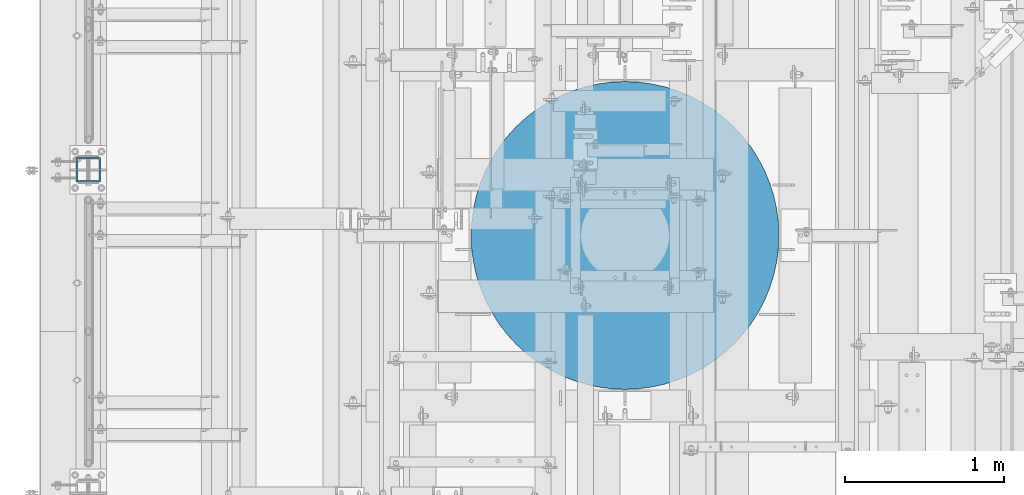
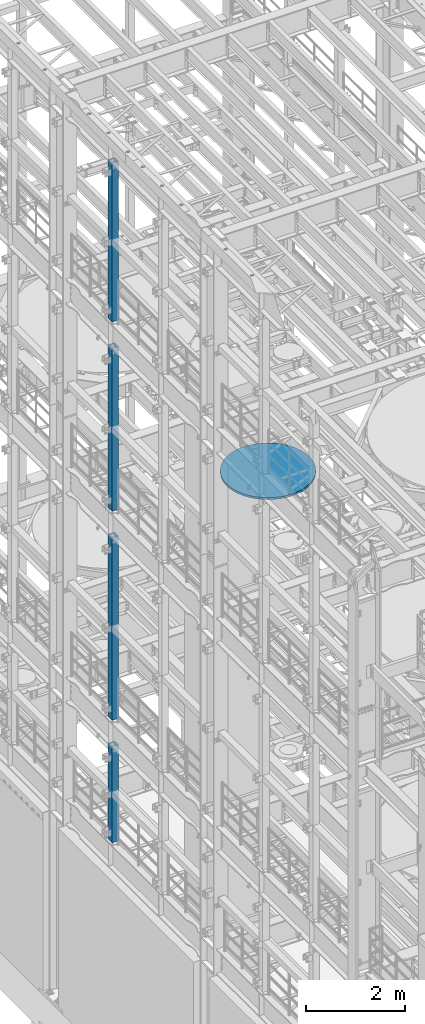
# One storey, part 703 of 1876: 6 columns, 6 elements without a shape of their own.
"""IFC2X3 building model written with IfcOpenShell, lengths in millimetres."""

import ifcopenshell
import ifcopenshell.guid

model = None  # the IFC model being written
_history = None  # IfcOwnerHistory: only IFC2X3 demands one
_inside = {}  # id of a spatial element -> (the spatial element, [elements in it])
_under = {}  # id of a project, library or spatial element -> (it, [spatial elements below it])
_declared = {}  # id of a project -> (the project, [libraries it declares])
_typed = {}  # id of a type object -> (the type object, [elements of that type])
_made_of = {}  # id of a material, layer set ... -> (it, [elements and type objects made of it])


def new_model(schema):
    """Start an empty IFC model of exactly this schema.

    Asked for "IFC4X3", IfcOpenShell would pick the latest addendum, in which some entities
    have other attributes; the version numbers below select the first issue.
    IFC2X3 requires an IfcOwnerHistory on every rooted entity: one is made here for all.
    """
    global model, _history
    if schema == "IFC4X3":
        model = ifcopenshell.file(schema_version=(4, 3, 0, 0))
    else:
        model = ifcopenshell.file(schema=schema)
    _inside.clear()
    _under.clear()
    _declared.clear()
    _typed.clear()
    _made_of.clear()
    _history = None
    if model.schema == "IFC2X3":
        org = make("IfcOrganization", Name="unknown")
        user = make(
            "IfcPersonAndOrganization",
            ThePerson=make("IfcPerson", FamilyName="unknown"),
            TheOrganization=org,
        )
        app = make(
            "IfcApplication",
            ApplicationDeveloper=org,
            Version="unknown",
            ApplicationFullName="unknown",
            ApplicationIdentifier="unknown",
        )
        _history = make(
            "IfcOwnerHistory",
            OwningUser=user,
            OwningApplication=app,
            ChangeAction="ADDED",
            CreationDate=0,
        )
    return model


def make(cls, **values):
    """One entity of the class cls with the attributes given. An attribute that is None is left unset."""
    return model.create_entity(
        cls, **{name: value for name, value in values.items() if value is not None}
    )


def rooted(cls, **values):
    """An entity with a GlobalId (a new one), such as an element, a storey or a relation."""
    return make(cls, GlobalId=ifcopenshell.guid.new(), OwnerHistory=_history, **values)


def si_unit(unit_type, name, prefix=None):
    """IfcSIUnit, for example si_unit("LENGTHUNIT", "METRE", prefix="MILLI")."""
    return make("IfcSIUnit", UnitType=unit_type, Prefix=prefix, Name=name)


def assignment(units):
    """IfcUnitAssignment: the units of a project."""
    return None if units is None else make("IfcUnitAssignment", Units=units)


def point(xyz):
    """IfcCartesianPoint."""
    return None if xyz is None else make("IfcCartesianPoint", Coordinates=xyz)


def direction(xyz):
    """IfcDirection."""
    return None if xyz is None else make("IfcDirection", DirectionRatios=xyz)


def frame(location, z_axis=None, x_axis=None):
    """IfcAxis2Placement3D, a coordinate frame: its origin and axes. An axis left out is left unset."""
    return make(
        "IfcAxis2Placement3D",
        Location=point(location),
        Axis=direction(z_axis),
        RefDirection=direction(x_axis),
    )


def origin_with_axes():
    """The frame at (0, 0, 0) with the z axis (0, 0, 1) and the x axis (1, 0, 0) written out."""
    return frame((0.0, 0.0, 0.0), z_axis=(0.0, 0.0, 1.0), x_axis=(1.0, 0.0, 0.0))


def place(relative_to, where):
    """IfcLocalPlacement: puts the frame where relative to a parent placement (None: the world)."""
    return make(
        "IfcLocalPlacement", PlacementRelTo=relative_to, RelativePlacement=where
    )


def context(
    kind, dimensions, precision=None, world=None, true_north=None, identifier=None
):
    """IfcGeometricRepresentationContext, for example the 3D "Model" context."""
    return make(
        "IfcGeometricRepresentationContext",
        ContextIdentifier=identifier,
        ContextType=kind,
        CoordinateSpaceDimension=dimensions,
        Precision=precision,
        WorldCoordinateSystem=world,
        TrueNorth=true_north,
    )


def subcontext(parent, identifier, kind, view, scale=None):
    """IfcGeometricRepresentationSubContext, for example "Body" below "Model"."""
    return make(
        "IfcGeometricRepresentationSubContext",
        ContextIdentifier=identifier,
        ContextType=kind,
        ParentContext=parent,
        TargetScale=scale,
        TargetView=view,
    )


def project(units=None, contexts=None):
    """IfcProject with its units and contexts."""
    return rooted(
        "IfcProject",
        Name="project",
        RepresentationContexts=contexts,
        UnitsInContext=assignment(units),
    )


def spatial(cls, under=None, at=None, **own):
    """A site, building, storey or space (cls), placed at a placement, below another one or the project."""
    s = rooted(cls, ObjectPlacement=at, **own)
    if under is not None:
        _under.setdefault(under.id(), (under, []))[1].append(s)
    return s


def faces_of(points, faces, orient=None, outer=None):
    """IfcFace entities. A face is a list of loops; a loop is a list of indices into points, from 0.

    orient and outer hold one flag for each loop. By default every Orientation is true, the
    first loop of a face is its IfcFaceOuterBound and the others are IfcFaceBound.
    """
    made = []
    for i, loops in enumerate(faces):
        bounds = []
        for j, loop in enumerate(loops):
            is_outer = j == 0 if outer is None else outer[i][j]
            bounds.append(
                make(
                    "IfcFaceOuterBound" if is_outer else "IfcFaceBound",
                    Bound=make("IfcPolyLoop", Polygon=[points[k] for k in loop]),
                    Orientation=True if orient is None else orient[i][j],
                )
            )
        made.append(make("IfcFace", Bounds=bounds))
    return made


def faceted_brep(points, faces, orient=None, outer=None, voids=None):
    """IfcFacetedBrep: a solid bounded by flat faces; with voids (closed shells), ...WithVoids."""
    shared = [point(p) for p in points]
    hull = make("IfcClosedShell", CfsFaces=faces_of(shared, faces, orient, outer))
    if voids is None:
        return make("IfcFacetedBrep", Outer=hull)
    return make(
        "IfcFacetedBrepWithVoids",
        Outer=hull,
        Voids=[
            make(cls, CfsFaces=faces_of(shared, fs, o, b)) for cls, fs, o, b in voids
        ],
    )


def shape(context_of_items, identifier, shape_type, items):
    """IfcShapeRepresentation: the items that make up one representation, for example the "Body"."""
    return make(
        "IfcShapeRepresentation",
        ContextOfItems=context_of_items,
        RepresentationIdentifier=identifier,
        RepresentationType=shape_type,
        Items=items,
    )


def material(Name=None, Category=None):
    """IfcMaterial."""
    return make("IfcMaterial", Name=Name, Category=Category)


def made_of(thing, what):
    """Note that an element or type object is made of a material, layer set ...; save() writes the relation."""
    if what is not None:
        _made_of.setdefault(what.id(), (what, []))[1].append(thing)
    return thing


def type_object(cls, material=None, **own):
    """A type object (cls), such as IfcWallType, which elements share."""
    return made_of(rooted(cls, **own), material)


def element(
    cls,
    number,
    at=None,
    inside=None,
    cuts=None,
    type_object=None,
    material=None,
    context=None,
    identifier="Body",
    shape_type=None,
    held_by="IfcProductDefinitionShape",
    body=None,
    shapes=None,
    **own,
):
    """One element of the class cls, such as IfcWall. Its Tag is "e" and its number.

    at: its placement. inside: the storey or other place that contains it. cuts: it is an
    opening in that element (IfcRelVoidsElement). A single representation is given by context,
    identifier, shape_type and body (its items); several are given by shapes. held_by: the class
    of the entity that holds the representations. save() writes the other relations.
    """
    e = rooted(cls, Tag="e%d" % number, ObjectPlacement=at, **own)
    if body is not None:
        shapes = [shape(context, identifier, shape_type, body)]
    if shapes is not None:
        e.Representation = make(held_by, Representations=shapes)
    if inside is not None:
        _inside.setdefault(inside.id(), (inside, []))[1].append(e)
    if cuts is not None:
        rooted(
            "IfcRelVoidsElement", RelatingBuildingElement=cuts, RelatedOpeningElement=e
        )
    if type_object is not None:
        _typed.setdefault(type_object.id(), (type_object, []))[1].append(e)
    return made_of(e, material)


def aggregate(whole, parts):
    """IfcRelAggregates: a whole, such as a stair, and the parts it consists of."""
    return rooted("IfcRelAggregates", RelatingObject=whole, RelatedObjects=parts)


def save(model, path):
    """Write the relations noted so far, then the file.

    IfcRelAggregates (storeys below a building ...), IfcRelContainedInSpatialStructure (elements
    in a storey), IfcRelDefinesByType, IfcRelAssociatesMaterial and IfcRelDeclares: one each for
    every whole, place, type object, material and project.
    """
    for whole, parts in _under.values():
        aggregate(whole, parts)
    for where, things in _inside.values():
        rooted(
            "IfcRelContainedInSpatialStructure",
            RelatedElements=things,
            RelatingStructure=where,
        )
    for kind, things in _typed.values():
        rooted("IfcRelDefinesByType", RelatedObjects=things, RelatingType=kind)
    for what, things in _made_of.values():
        rooted("IfcRelAssociatesMaterial", RelatedObjects=things, RelatingMaterial=what)
    for by, libraries in _declared.values():
        rooted("IfcRelDeclares", RelatingContext=by, RelatedDefinitions=libraries)
    model.write(path)


model = new_model("IFC2X3")

# Units and contexts
model_context = context("Model", 3, precision=1e-05, world=origin_with_axes())
body_context = subcontext(model_context, "Body", "Model", "MODEL_VIEW")
ifc_project = project(units=[si_unit("LENGTHUNIT", "METRE", prefix="MILLI"), si_unit("AREAUNIT", "SQUARE_METRE"), si_unit("VOLUMEUNIT", "CUBIC_METRE"), si_unit("MASSUNIT", "GRAM", prefix="KILO"), si_unit("TIMEUNIT", "SECOND"), si_unit("PLANEANGLEUNIT", "RADIAN"), si_unit("SOLIDANGLEUNIT", "STERADIAN"), si_unit("THERMODYNAMICTEMPERATUREUNIT", "DEGREE_CELSIUS"), si_unit("LUMINOUSINTENSITYUNIT", "LUMEN")], contexts=[model_context])

# Site, building, storey
site_placement = place(None, origin_with_axes())
site = spatial("IfcSite", under=ifc_project, at=site_placement, CompositionType="ELEMENT")
building_placement = place(site_placement, origin_with_axes())
building = spatial("IfcBuilding", under=site, at=building_placement, Name="Undefined", CompositionType="ELEMENT")
storey_placement = place(building_placement, origin_with_axes())
storey = spatial("IfcBuildingStorey", under=building, at=storey_placement, Name="Undefined", CompositionType="ELEMENT", Elevation=0.0)

# Assembly, column
assembly_1_placement = place(storey_placement, origin_with_axes())
assembly_1 = element("IfcElementAssembly", 1, at=assembly_1_placement, inside=storey, Name="BEAM", AssemblyPlace="NOTDEFINED", PredefinedType="RIGID_FRAME")
ifc_material_1 = material()
column_type_1 = type_object("IfcColumnType", Name="HSS6X6X3/8", PredefinedType="NOTDEFINED")
column_1_placement = place(assembly_1_placement, frame((0.0, 5588.0, 17983.2), z_axis=(-1.0, 0.0, 0.0), x_axis=(0.0, 0.0, 1.0)))
column_1 = element("IfcColumn", 2, at=column_1_placement, type_object=column_type_1, material=ifc_material_1, Name="COLUMN", ObjectType="HSS6X6X3/8", context=body_context, shape_type="Brep", body=[
    faceted_brep([(12.7000000000016, 66.6750000000002, -66.6750000000002), (12.7000000000016, -66.6750000000002, -66.6750000000002), (3937.0, -66.6750000000002, -66.675), (3937.0, 66.6750000000002, -66.675), (12.7000000000016, -66.6750000000002, 66.6750000000002), (3937.0, -66.6750000000002, 66.675), (12.7000000000016, 66.6750000000002, 66.6750000000002), (3937.0, 66.6750000000002, 66.675), (12.7000000000016, 76.1999999999998, -76.1999999999998), (12.7000000000016, 76.1999999999998, 76.1999999999998), (3937.0, 76.1999999999998, 76.2), (3937.0, 76.1999999999998, -76.2), (12.7000000000016, -76.1999999999998, 76.1999999999998), (3937.0, -76.1999999999998, 76.2), (12.7000000000016, -76.1999999999998, -76.1999999999998), (3937.0, -76.1999999999998, -76.2)], [[[0, 1, 2, 3]], [[1, 4, 5, 2]], [[4, 6, 7, 5]], [[6, 0, 3, 7]], [[8, 9, 10, 11]], [[9, 12, 13, 10]], [[12, 14, 15, 13]], [[14, 8, 11, 15]], [[13, 15, 11, 10], [5, 7, 3, 2]], [[14, 12, 9, 8], [6, 4, 1, 0]]]),
])
aggregate(assembly_1, [column_1])

assembly_2_placement = place(storey_placement, origin_with_axes())
assembly_2 = element("IfcElementAssembly", 3, at=assembly_2_placement, inside=storey, Name="BEAM", AssemblyPlace="NOTDEFINED", PredefinedType="RIGID_FRAME")
column_2_placement = place(assembly_2_placement, frame((0.0, 5588.0, 13309.6), z_axis=(-1.0, 0.0, 0.0), x_axis=(0.0, 0.0, 1.0)))
column_2 = element("IfcColumn", 4, at=column_2_placement, type_object=column_type_1, material=ifc_material_1, Name="COLUMN", ObjectType="HSS6X6X3/8", context=body_context, shape_type="Brep", body=[
    faceted_brep([(12.7000000000016, 66.6750000000002, -66.6750000000002), (12.7000000000016, -66.6750000000002, -66.6750000000002), (4038.6, -66.6750000000002, -66.675), (4038.6, 66.6750000000002, -66.675), (12.7000000000016, -66.6750000000002, 66.6750000000002), (4038.6, -66.6750000000002, 66.675), (12.7000000000016, 66.6750000000002, 66.6750000000002), (4038.6, 66.6750000000002, 66.675), (12.7000000000016, 76.1999999999998, -76.1999999999998), (12.7000000000016, 76.1999999999998, 76.1999999999998), (4038.6, 76.1999999999998, 76.2), (4038.6, 76.1999999999998, -76.2), (12.7000000000016, -76.1999999999998, 76.1999999999998), (4038.6, -76.1999999999998, 76.2), (12.7000000000016, -76.1999999999998, -76.1999999999998), (4038.6, -76.1999999999998, -76.2)], [[[0, 1, 2, 3]], [[1, 4, 5, 2]], [[4, 6, 7, 5]], [[6, 0, 3, 7]], [[8, 9, 10, 11]], [[9, 12, 13, 10]], [[12, 14, 15, 13]], [[14, 8, 11, 15]], [[13, 15, 11, 10], [5, 7, 3, 2]], [[14, 12, 9, 8], [6, 4, 1, 0]]]),
])
aggregate(assembly_2, [column_2])

assembly_3_placement = place(storey_placement, origin_with_axes())
assembly_3 = element("IfcElementAssembly", 5, at=assembly_3_placement, inside=storey, Name="BEAM", AssemblyPlace="NOTDEFINED", PredefinedType="RIGID_FRAME")
column_3_placement = place(assembly_3_placement, frame((0.0, 5588.0, 8153.4), z_axis=(-0.999999999563517, 0.0, -2.95459999870218e-05), x_axis=(-2.95459999861759e-05, 0.0, 0.999999999563517)))
column_3 = element("IfcColumn", 6, at=column_3_placement, type_object=column_type_1, material=ifc_material_1, Name="COLUMN", ObjectType="HSS6X6X3/8", context=body_context, shape_type="Brep", body=[
    faceted_brep([(12.698030025992, 66.6750000000002, -66.675), (12.698030025992, -66.6750000000002, -66.675), (4521.2007045434, -66.6750000000002, -66.675), (4521.2007045434, 66.6750000000002, -66.675), (12.7019699850925, -66.6750000000002, 66.675), (4521.20070454334, -66.6750000000002, 66.675), (12.7019699850925, 66.6750000000002, 66.675), (4521.20070454334, 66.6750000000002, 66.675), (12.6977486003425, 76.1999999999998, -76.2), (12.7022514107421, 76.1999999999998, 76.2), (4521.20070454334, 76.1999999999998, 76.2), (4521.2007045434, 76.1999999999998, -76.2), (12.7022514107421, -76.1999999999998, 76.2), (4521.20070454334, -76.1999999999998, 76.2), (12.6977486003425, -76.1999999999998, -76.2), (4521.2007045434, -76.1999999999998, -76.2)], [[[0, 1, 2, 3]], [[1, 4, 5, 2]], [[4, 6, 7, 5]], [[6, 0, 3, 7]], [[8, 9, 10, 11]], [[9, 12, 13, 10]], [[12, 14, 15, 13]], [[14, 8, 11, 15]], [[13, 15, 11, 10], [5, 7, 3, 2]], [[14, 12, 9, 8], [6, 4, 1, 0]]]),
])
aggregate(assembly_3, [column_3])

assembly_4_placement = place(storey_placement, origin_with_axes())
assembly_4 = element("IfcElementAssembly", 7, at=assembly_4_placement, inside=storey, Name="BEAM", AssemblyPlace="NOTDEFINED", PredefinedType="RIGID_FRAME")
column_4_placement = place(assembly_4_placement, frame((0.0, 5588.0, 5130.8), z_axis=(-0.999999998434855, 0.0, -5.59490000241567e-05), x_axis=(-5.59490000243298e-05, 0.0, 0.999999998434855)))
column_4 = element("IfcColumn", 8, at=column_4_placement, type_object=column_type_1, material=ifc_material_1, Name="COLUMN", ObjectType="HSS6X6X3/8", context=body_context, shape_type="Brep", body=[
    faceted_brep([(12.6962696202891, 66.6750000000002, -66.675), (12.6962696202891, -66.6750000000002, -66.675), (2387.60070630699, -66.6750000000002, -66.675), (2387.60070630699, 66.6750000000002, -66.675), (12.7037304194646, -66.6750000000002, 66.675), (2387.600706307, -66.6750000000002, 66.675), (12.7037304194646, 66.6750000000002, 66.675), (2387.600706307, 66.6750000000002, 66.675), (12.6957367060613, 76.1999999999998, -76.2), (12.7042633336914, 76.1999999999998, 76.2), (2387.600706307, 76.1999999999998, 76.2), (2387.60070630699, 76.1999999999998, -76.2), (12.7042633336914, -76.1999999999998, 76.2), (2387.600706307, -76.1999999999998, 76.2), (12.6957367060613, -76.1999999999998, -76.2), (2387.60070630699, -76.1999999999998, -76.2)], [[[0, 1, 2, 3]], [[1, 4, 5, 2]], [[4, 6, 7, 5]], [[6, 0, 3, 7]], [[8, 9, 10, 11]], [[9, 12, 13, 10]], [[12, 14, 15, 13]], [[14, 8, 11, 15]], [[13, 15, 11, 10], [5, 7, 3, 2]], [[14, 12, 9, 8], [6, 4, 1, 0]]]),
])
aggregate(assembly_4, [column_4])

assembly_5_placement = place(storey_placement, origin_with_axes())
assembly_5 = element("IfcElementAssembly", 9, at=assembly_5_placement, inside=storey, Name="COLUMN", AssemblyPlace="NOTDEFINED", PredefinedType="REINFORCEMENT_UNIT")
ifc_material_2 = material(Name="CONCRETE/3000")
column_type_2 = type_object("IfcColumnType", PredefinedType="NOTDEFINED")
column_5_placement = place(assembly_5_placement, frame((3371.85, 5175.25, 13284.2), z_axis=(-1.0, 0.0, 0.0), x_axis=(0.0, 0.0, 1.0)))
column_5 = element("IfcColumn", 10, at=column_5_placement, type_object=column_type_2, material=ifc_material_2, Name="COLUMN", context=body_context, shape_type="Brep", body=[
    faceted_brep([(0.0, -966.7875, 0.0), (0.0, -963.108581681374, -84.2610826416517), (50.7999999999993, -963.108581681374, -84.2610826416517), (50.7999999999993, -966.7875, 0.0), (0.0, -952.09982551529, -167.880887566168), (50.7999999999993, -952.09982551529, -167.880887566168), (0.0, -933.845014783443, -250.223017567053), (50.7999999999993, -933.845014783443, -250.223017567053), (0.0, -908.483079618056, -330.660799315466), (50.7999999999993, -908.483079618056, -330.660799315466), (0.0, -876.207039659696, -408.582052722637), (50.7999999999993, -876.207039659696, -408.582052722637), (0.0, -837.262535061248, -483.393750000001), (50.7999999999993, -837.262535061248, -483.393750000001), (0.0, -791.945957018043, -554.526528958737), (50.7999999999993, -791.945957018043, -554.526528958737), (0.0, -740.602192051889, -621.439026199826), (50.7999999999993, -740.602192051889, -621.439026199826), (0.0, -683.621997216389, -683.621997216389), (50.7999999999993, -683.621997216389, -683.621997216389), (0.0, -621.439026199825, -740.602192051889), (50.7999999999993, -621.439026199825, -740.602192051889), (0.0, -554.526528958737, -791.945957018043), (50.7999999999993, -554.526528958737, -791.945957018043), (0.0, -483.39375, -837.262535061248), (50.7999999999993, -483.39375, -837.262535061248), (0.0, -408.582052722636, -876.207039659696), (50.7999999999993, -408.582052722636, -876.207039659696), (0.0, -330.660799315465, -908.483079618057), (50.7999999999993, -330.660799315465, -908.483079618057), (0.0, -250.223017567053, -933.845014783443), (50.7999999999993, -250.223017567053, -933.845014783443), (0.0, -167.880887566167, -952.09982551529), (50.7999999999993, -167.880887566167, -952.09982551529), (0.0, -84.2610826416512, -963.108581681374), (50.7999999999993, -84.2610826416512, -963.108581681374), (0.0, 0.0, -966.7875), (50.7999999999993, 0.0, -966.7875), (0.0, 84.2610826416512, -963.108581681374), (50.7999999999993, 84.2610826416512, -963.108581681374), (0.0, 167.880887566167, -952.09982551529), (50.7999999999993, 167.880887566167, -952.09982551529), (0.0, 250.223017567053, -933.845014783443), (50.7999999999993, 250.223017567053, -933.845014783443), (0.0, 330.660799315466, -908.483079618056), (50.7999999999993, 330.660799315466, -908.483079618056), (0.0, 408.582052722637, -876.207039659696), (50.7999999999993, 408.582052722637, -876.207039659696), (0.0, 483.39375, -837.262535061248), (50.7999999999993, 483.39375, -837.262535061248), (0.0, 554.526528958737, -791.945957018043), (50.7999999999993, 554.526528958737, -791.945957018043), (0.0, 621.439026199825, -740.602192051889), (50.7999999999993, 621.439026199825, -740.602192051889), (0.0, 683.621997216389, -683.621997216389), (50.7999999999993, 683.621997216389, -683.621997216389), (0.0, 740.602192051889, -621.439026199825), (50.7999999999993, 740.602192051889, -621.439026199825), (0.0, 791.945957018044, -554.526528958737), (50.7999999999993, 791.945957018044, -554.526528958737), (0.0, 837.262535061248, -483.39375), (50.7999999999993, 837.262535061248, -483.39375), (0.0, 876.207039659696, -408.582052722636), (50.7999999999993, 876.207039659696, -408.582052722636), (0.0, 908.483079618057, -330.660799315465), (50.7999999999993, 908.483079618057, -330.660799315465), (0.0, 933.845014783443, -250.223017567053), (50.7999999999993, 933.845014783443, -250.223017567053), (0.0, 952.09982551529, -167.880887566167), (50.7999999999993, 952.09982551529, -167.880887566167), (0.0, 963.108581681374, -84.2610826416512), (50.7999999999993, 963.108581681374, -84.2610826416512), (0.0, 966.7875, 0.0), (50.7999999999993, 966.7875, 0.0), (0.0, 963.108581681374, 84.2610826416517), (50.7999999999993, 963.108581681374, 84.2610826416517), (0.0, 952.09982551529, 167.880887566168), (50.7999999999993, 952.09982551529, 167.880887566168), (0.0, 933.845014783443, 250.223017567053), (50.7999999999993, 933.845014783443, 250.223017567053), (0.0, 908.483079618056, 330.660799315465), (50.7999999999993, 908.483079618056, 330.660799315465), (0.0, 876.207039659696, 408.582052722636), (50.7999999999993, 876.207039659696, 408.582052722636), (0.0, 837.262535061248, 483.39375), (50.7999999999993, 837.262535061248, 483.39375), (0.0, 791.945957018043, 554.526528958737), (50.7999999999993, 791.945957018043, 554.526528958737), (0.0, 740.602192051889, 621.439026199825), (50.7999999999993, 740.602192051889, 621.439026199825), (0.0, 683.621997216389, 683.621997216389), (50.7999999999993, 683.621997216389, 683.621997216389), (0.0, 621.439026199825, 740.602192051889), (50.7999999999993, 621.439026199825, 740.602192051889), (0.0, 554.526528958737, 791.945957018044), (50.7999999999993, 554.526528958737, 791.945957018044), (0.0, 483.39375, 837.262535061248), (50.7999999999993, 483.39375, 837.262535061248), (0.0, 408.582052722636, 876.207039659696), (50.7999999999993, 408.582052722636, 876.207039659696), (0.0, 330.660799315465, 908.483079618056), (50.7999999999993, 330.660799315465, 908.483079618056), (0.0, 250.223017567053, 933.845014783443), (50.7999999999993, 250.223017567053, 933.845014783443), (0.0, 167.880887566167, 952.09982551529), (50.7999999999993, 167.880887566167, 952.09982551529), (0.0, 84.2610826416512, 963.108581681373), (50.7999999999993, 84.2610826416512, 963.108581681373), (0.0, 0.0, 966.7875), (50.7999999999993, 0.0, 966.7875), (0.0, -84.2610826416521, 963.108581681373), (50.7999999999993, -84.2610826416521, 963.108581681373), (0.0, -167.880887566167, 952.09982551529), (50.7999999999993, -167.880887566167, 952.09982551529), (0.0, -250.223017567053, 933.845014783443), (50.7999999999993, -250.223017567053, 933.845014783443), (0.0, -330.660799315465, 908.483079618056), (50.7999999999993, -330.660799315465, 908.483079618056), (0.0, -408.582052722637, 876.207039659695), (50.7999999999993, -408.582052722637, 876.207039659695), (0.0, -483.39375, 837.262535061248), (50.7999999999993, -483.39375, 837.262535061248), (0.0, -554.526528958737, 791.945957018044), (50.7999999999993, -554.526528958737, 791.945957018044), (0.0, -621.439026199825, 740.602192051889), (50.7999999999993, -621.439026199825, 740.602192051889), (0.0, -683.621997216389, 683.621997216389), (50.7999999999993, -683.621997216389, 683.621997216389), (0.0, -740.602192051889, 621.439026199825), (50.7999999999993, -740.602192051889, 621.439026199825), (0.0, -791.945957018043, 554.526528958737), (50.7999999999993, -791.945957018043, 554.526528958737), (0.0, -837.262535061248, 483.39375), (50.7999999999993, -837.262535061248, 483.39375), (0.0, -876.207039659696, 408.582052722636), (50.7999999999993, -876.207039659696, 408.582052722636), (0.0, -908.483079618057, 330.660799315465), (50.7999999999993, -908.483079618057, 330.660799315465), (0.0, -933.845014783443, 250.223017567053), (50.7999999999993, -933.845014783443, 250.223017567053), (0.0, -952.09982551529, 167.880887566168), (50.7999999999993, -952.09982551529, 167.880887566168), (0.0, -963.108581681374, 84.2610826416517), (50.7999999999993, -963.108581681374, 84.2610826416517)], [[[0, 1, 2, 3]], [[1, 4, 5, 2]], [[4, 6, 7, 5]], [[6, 8, 9, 7]], [[8, 10, 11, 9]], [[10, 12, 13, 11]], [[12, 14, 15, 13]], [[14, 16, 17, 15]], [[16, 18, 19, 17]], [[18, 20, 21, 19]], [[20, 22, 23, 21]], [[22, 24, 25, 23]], [[24, 26, 27, 25]], [[26, 28, 29, 27]], [[28, 30, 31, 29]], [[30, 32, 33, 31]], [[32, 34, 35, 33]], [[34, 36, 37, 35]], [[36, 38, 39, 37]], [[38, 40, 41, 39]], [[40, 42, 43, 41]], [[42, 44, 45, 43]], [[44, 46, 47, 45]], [[46, 48, 49, 47]], [[48, 50, 51, 49]], [[50, 52, 53, 51]], [[52, 54, 55, 53]], [[54, 56, 57, 55]], [[56, 58, 59, 57]], [[58, 60, 61, 59]], [[60, 62, 63, 61]], [[62, 64, 65, 63]], [[64, 66, 67, 65]], [[66, 68, 69, 67]], [[68, 70, 71, 69]], [[70, 72, 73, 71]], [[72, 74, 75, 73]], [[74, 76, 77, 75]], [[76, 78, 79, 77]], [[78, 80, 81, 79]], [[80, 82, 83, 81]], [[82, 84, 85, 83]], [[84, 86, 87, 85]], [[86, 88, 89, 87]], [[88, 90, 91, 89]], [[90, 92, 93, 91]], [[92, 94, 95, 93]], [[94, 96, 97, 95]], [[96, 98, 99, 97]], [[98, 100, 101, 99]], [[100, 102, 103, 101]], [[102, 104, 105, 103]], [[104, 106, 107, 105]], [[106, 108, 109, 107]], [[108, 110, 111, 109]], [[110, 112, 113, 111]], [[112, 114, 115, 113]], [[114, 116, 117, 115]], [[116, 118, 119, 117]], [[118, 120, 121, 119]], [[120, 122, 123, 121]], [[122, 124, 125, 123]], [[124, 126, 127, 125]], [[126, 128, 129, 127]], [[128, 130, 131, 129]], [[130, 132, 133, 131]], [[132, 134, 135, 133]], [[134, 136, 137, 135]], [[136, 138, 139, 137]], [[138, 140, 141, 139]], [[140, 142, 143, 141]], [[142, 0, 3, 143]], [[5, 7, 9, 11, 13, 15, 17, 19, 21, 23, 25, 27, 29, 31, 33, 35, 37, 39, 41, 43, 45, 47, 49, 51, 53, 55, 57, 59, 61, 63, 65, 67, 69, 71, 73, 75, 77, 79, 81, 83, 85, 87, 89, 91, 93, 95, 97, 99, 101, 103, 105, 107, 109, 111, 113, 115, 117, 119, 121, 123, 125, 127, 129, 131, 133, 135, 137, 139, 141, 143, 3, 2]], [[142, 140, 138, 136, 134, 132, 130, 128, 126, 124, 122, 120, 118, 116, 114, 112, 110, 108, 106, 104, 102, 100, 98, 96, 94, 92, 90, 88, 86, 84, 82, 80, 78, 76, 74, 72, 70, 68, 66, 64, 62, 60, 58, 56, 54, 52, 50, 48, 46, 44, 42, 40, 38, 36, 34, 32, 30, 28, 26, 24, 22, 20, 18, 16, 14, 12, 10, 8, 6, 4, 1, 0]]]),
])
aggregate(assembly_5, [column_5])

assembly_6_placement = place(storey_placement, origin_with_axes())
assembly_6 = element("IfcElementAssembly", 11, at=assembly_6_placement, inside=storey, Name="COLUMN", AssemblyPlace="NOTDEFINED", PredefinedType="REINFORCEMENT_UNIT")
column_6_placement = place(assembly_6_placement, frame((3371.85, 5175.25, 13284.2), z_axis=(-1.0, 0.0, 0.0), x_axis=(0.0, 0.0, 1.0)))
column_6 = element("IfcColumn", 12, at=column_6_placement, type_object=column_type_2, material=ifc_material_2, Name="COLUMN", context=body_context, shape_type="Brep", body=[
    faceted_brep([(0.0, -966.7875, 0.0), (0.0, -963.108581681374, -84.2610826416517), (50.7999999999993, -963.108581681374, -84.2610826416517), (50.7999999999993, -966.7875, 0.0), (0.0, -952.09982551529, -167.880887566168), (50.7999999999993, -952.09982551529, -167.880887566168), (0.0, -933.845014783443, -250.223017567053), (50.7999999999993, -933.845014783443, -250.223017567053), (0.0, -908.483079618056, -330.660799315466), (50.7999999999993, -908.483079618056, -330.660799315466), (0.0, -876.207039659696, -408.582052722637), (50.7999999999993, -876.207039659696, -408.582052722637), (0.0, -837.262535061248, -483.393750000001), (50.7999999999993, -837.262535061248, -483.393750000001), (0.0, -791.945957018043, -554.526528958737), (50.7999999999993, -791.945957018043, -554.526528958737), (0.0, -740.602192051889, -621.439026199826), (50.7999999999993, -740.602192051889, -621.439026199826), (0.0, -683.621997216389, -683.621997216389), (50.7999999999993, -683.621997216389, -683.621997216389), (0.0, -621.439026199825, -740.602192051889), (50.7999999999993, -621.439026199825, -740.602192051889), (0.0, -554.526528958737, -791.945957018043), (50.7999999999993, -554.526528958737, -791.945957018043), (0.0, -483.39375, -837.262535061248), (50.7999999999993, -483.39375, -837.262535061248), (0.0, -408.582052722636, -876.207039659696), (50.7999999999993, -408.582052722636, -876.207039659696), (0.0, -330.660799315465, -908.483079618057), (50.7999999999993, -330.660799315465, -908.483079618057), (0.0, -250.223017567053, -933.845014783443), (50.7999999999993, -250.223017567053, -933.845014783443), (0.0, -167.880887566167, -952.09982551529), (50.7999999999993, -167.880887566167, -952.09982551529), (0.0, -84.2610826416512, -963.108581681374), (50.7999999999993, -84.2610826416512, -963.108581681374), (0.0, 0.0, -966.7875), (50.7999999999993, 0.0, -966.7875), (0.0, 84.2610826416512, -963.108581681374), (50.7999999999993, 84.2610826416512, -963.108581681374), (0.0, 167.880887566167, -952.09982551529), (50.7999999999993, 167.880887566167, -952.09982551529), (0.0, 250.223017567053, -933.845014783443), (50.7999999999993, 250.223017567053, -933.845014783443), (0.0, 330.660799315466, -908.483079618056), (50.7999999999993, 330.660799315466, -908.483079618056), (0.0, 408.582052722637, -876.207039659696), (50.7999999999993, 408.582052722637, -876.207039659696), (0.0, 483.39375, -837.262535061248), (50.7999999999993, 483.39375, -837.262535061248), (0.0, 554.526528958737, -791.945957018043), (50.7999999999993, 554.526528958737, -791.945957018043), (0.0, 621.439026199825, -740.602192051889), (50.7999999999993, 621.439026199825, -740.602192051889), (0.0, 683.621997216389, -683.621997216389), (50.7999999999993, 683.621997216389, -683.621997216389), (0.0, 740.602192051889, -621.439026199825), (50.7999999999993, 740.602192051889, -621.439026199825), (0.0, 791.945957018044, -554.526528958737), (50.7999999999993, 791.945957018044, -554.526528958737), (0.0, 837.262535061248, -483.39375), (50.7999999999993, 837.262535061248, -483.39375), (0.0, 876.207039659696, -408.582052722636), (50.7999999999993, 876.207039659696, -408.582052722636), (0.0, 908.483079618057, -330.660799315465), (50.7999999999993, 908.483079618057, -330.660799315465), (0.0, 933.845014783443, -250.223017567053), (50.7999999999993, 933.845014783443, -250.223017567053), (0.0, 952.09982551529, -167.880887566167), (50.7999999999993, 952.09982551529, -167.880887566167), (0.0, 963.108581681374, -84.2610826416512), (50.7999999999993, 963.108581681374, -84.2610826416512), (0.0, 966.7875, 0.0), (50.7999999999993, 966.7875, 0.0), (0.0, 963.108581681374, 84.2610826416517), (50.7999999999993, 963.108581681374, 84.2610826416517), (0.0, 952.09982551529, 167.880887566168), (50.7999999999993, 952.09982551529, 167.880887566168), (0.0, 933.845014783443, 250.223017567053), (50.7999999999993, 933.845014783443, 250.223017567053), (0.0, 908.483079618056, 330.660799315465), (50.7999999999993, 908.483079618056, 330.660799315465), (0.0, 876.207039659696, 408.582052722636), (50.7999999999993, 876.207039659696, 408.582052722636), (0.0, 837.262535061248, 483.39375), (50.7999999999993, 837.262535061248, 483.39375), (0.0, 791.945957018043, 554.526528958737), (50.7999999999993, 791.945957018043, 554.526528958737), (0.0, 740.602192051889, 621.439026199825), (50.7999999999993, 740.602192051889, 621.439026199825), (0.0, 683.621997216389, 683.621997216389), (50.7999999999993, 683.621997216389, 683.621997216389), (0.0, 621.439026199825, 740.602192051889), (50.7999999999993, 621.439026199825, 740.602192051889), (0.0, 554.526528958737, 791.945957018044), (50.7999999999993, 554.526528958737, 791.945957018044), (0.0, 483.39375, 837.262535061248), (50.7999999999993, 483.39375, 837.262535061248), (0.0, 408.582052722636, 876.207039659696), (50.7999999999993, 408.582052722636, 876.207039659696), (0.0, 330.660799315465, 908.483079618056), (50.7999999999993, 330.660799315465, 908.483079618056), (0.0, 250.223017567053, 933.845014783443), (50.7999999999993, 250.223017567053, 933.845014783443), (0.0, 167.880887566167, 952.09982551529), (50.7999999999993, 167.880887566167, 952.09982551529), (0.0, 84.2610826416512, 963.108581681373), (50.7999999999993, 84.2610826416512, 963.108581681373), (0.0, 0.0, 966.7875), (50.7999999999993, 0.0, 966.7875), (0.0, -84.2610826416521, 963.108581681373), (50.7999999999993, -84.2610826416521, 963.108581681373), (0.0, -167.880887566167, 952.09982551529), (50.7999999999993, -167.880887566167, 952.09982551529), (0.0, -250.223017567053, 933.845014783443), (50.7999999999993, -250.223017567053, 933.845014783443), (0.0, -330.660799315465, 908.483079618056), (50.7999999999993, -330.660799315465, 908.483079618056), (0.0, -408.582052722637, 876.207039659695), (50.7999999999993, -408.582052722637, 876.207039659695), (0.0, -483.39375, 837.262535061248), (50.7999999999993, -483.39375, 837.262535061248), (0.0, -554.526528958737, 791.945957018044), (50.7999999999993, -554.526528958737, 791.945957018044), (0.0, -621.439026199825, 740.602192051889), (50.7999999999993, -621.439026199825, 740.602192051889), (0.0, -683.621997216389, 683.621997216389), (50.7999999999993, -683.621997216389, 683.621997216389), (0.0, -740.602192051889, 621.439026199825), (50.7999999999993, -740.602192051889, 621.439026199825), (0.0, -791.945957018043, 554.526528958737), (50.7999999999993, -791.945957018043, 554.526528958737), (0.0, -837.262535061248, 483.39375), (50.7999999999993, -837.262535061248, 483.39375), (0.0, -876.207039659696, 408.582052722636), (50.7999999999993, -876.207039659696, 408.582052722636), (0.0, -908.483079618057, 330.660799315465), (50.7999999999993, -908.483079618057, 330.660799315465), (0.0, -933.845014783443, 250.223017567053), (50.7999999999993, -933.845014783443, 250.223017567053), (0.0, -952.09982551529, 167.880887566168), (50.7999999999993, -952.09982551529, 167.880887566168), (0.0, -963.108581681374, 84.2610826416517), (50.7999999999993, -963.108581681374, 84.2610826416517)], [[[0, 1, 2, 3]], [[1, 4, 5, 2]], [[4, 6, 7, 5]], [[6, 8, 9, 7]], [[8, 10, 11, 9]], [[10, 12, 13, 11]], [[12, 14, 15, 13]], [[14, 16, 17, 15]], [[16, 18, 19, 17]], [[18, 20, 21, 19]], [[20, 22, 23, 21]], [[22, 24, 25, 23]], [[24, 26, 27, 25]], [[26, 28, 29, 27]], [[28, 30, 31, 29]], [[30, 32, 33, 31]], [[32, 34, 35, 33]], [[34, 36, 37, 35]], [[36, 38, 39, 37]], [[38, 40, 41, 39]], [[40, 42, 43, 41]], [[42, 44, 45, 43]], [[44, 46, 47, 45]], [[46, 48, 49, 47]], [[48, 50, 51, 49]], [[50, 52, 53, 51]], [[52, 54, 55, 53]], [[54, 56, 57, 55]], [[56, 58, 59, 57]], [[58, 60, 61, 59]], [[60, 62, 63, 61]], [[62, 64, 65, 63]], [[64, 66, 67, 65]], [[66, 68, 69, 67]], [[68, 70, 71, 69]], [[70, 72, 73, 71]], [[72, 74, 75, 73]], [[74, 76, 77, 75]], [[76, 78, 79, 77]], [[78, 80, 81, 79]], [[80, 82, 83, 81]], [[82, 84, 85, 83]], [[84, 86, 87, 85]], [[86, 88, 89, 87]], [[88, 90, 91, 89]], [[90, 92, 93, 91]], [[92, 94, 95, 93]], [[94, 96, 97, 95]], [[96, 98, 99, 97]], [[98, 100, 101, 99]], [[100, 102, 103, 101]], [[102, 104, 105, 103]], [[104, 106, 107, 105]], [[106, 108, 109, 107]], [[108, 110, 111, 109]], [[110, 112, 113, 111]], [[112, 114, 115, 113]], [[114, 116, 117, 115]], [[116, 118, 119, 117]], [[118, 120, 121, 119]], [[120, 122, 123, 121]], [[122, 124, 125, 123]], [[124, 126, 127, 125]], [[126, 128, 129, 127]], [[128, 130, 131, 129]], [[130, 132, 133, 131]], [[132, 134, 135, 133]], [[134, 136, 137, 135]], [[136, 138, 139, 137]], [[138, 140, 141, 139]], [[140, 142, 143, 141]], [[142, 0, 3, 143]], [[5, 7, 9, 11, 13, 15, 17, 19, 21, 23, 25, 27, 29, 31, 33, 35, 37, 39, 41, 43, 45, 47, 49, 51, 53, 55, 57, 59, 61, 63, 65, 67, 69, 71, 73, 75, 77, 79, 81, 83, 85, 87, 89, 91, 93, 95, 97, 99, 101, 103, 105, 107, 109, 111, 113, 115, 117, 119, 121, 123, 125, 127, 129, 131, 133, 135, 137, 139, 141, 143, 3, 2]], [[142, 140, 138, 136, 134, 132, 130, 128, 126, 124, 122, 120, 118, 116, 114, 112, 110, 108, 106, 104, 102, 100, 98, 96, 94, 92, 90, 88, 86, 84, 82, 80, 78, 76, 74, 72, 70, 68, 66, 64, 62, 60, 58, 56, 54, 52, 50, 48, 46, 44, 42, 40, 38, 36, 34, 32, 30, 28, 26, 24, 22, 20, 18, 16, 14, 12, 10, 8, 6, 4, 1, 0]]]),
])
aggregate(assembly_6, [column_6])

save(model, "model.ifc")
